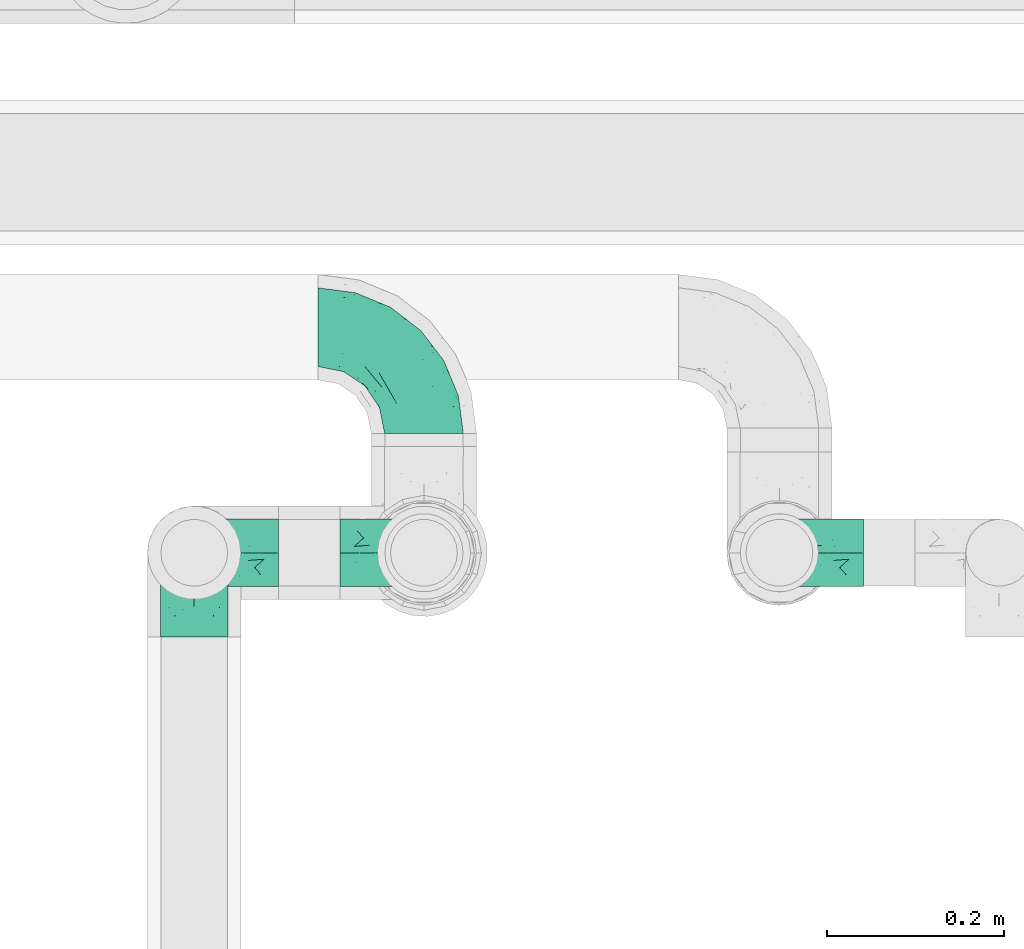
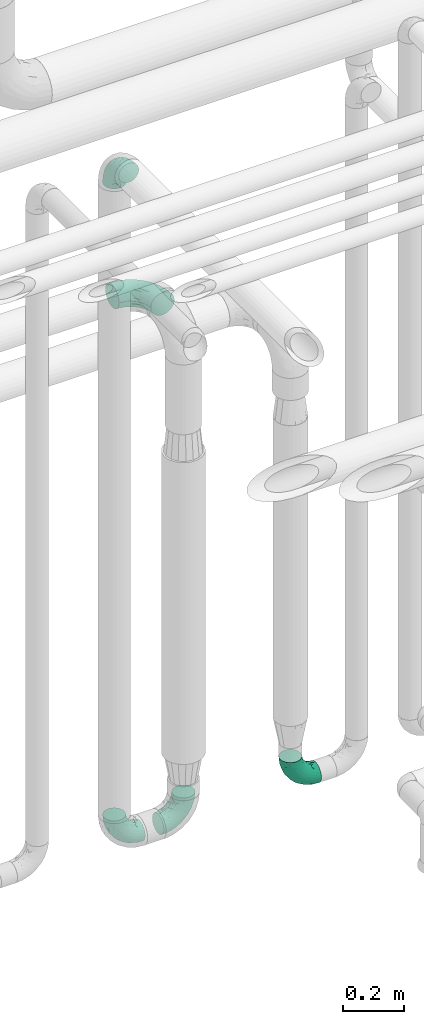
# One storey, part 709 of 824: 5 flow fittings.
"""IFC2X3 building model written with IfcOpenShell, lengths in millimetres."""

from ifc_helpers import new_model, entity, si_unit, converted_unit, derived_unit, direction, frame, origin, place, context, subcontext, project, spatial, faceted_brep, source, transform, mapped, material, type_object, type_shapes, element, save


model = new_model("IFC2X3")

# Units and contexts
model_context = context("Model", 3, precision=0.01, world=origin(), true_north=direction((6.12303176911189e-17, 1.0)))
body_context = subcontext(model_context, "Body", "Model", "MODEL_VIEW")
ifc_project = project(units=[si_unit("LENGTHUNIT", "METRE", prefix="MILLI"), si_unit("AREAUNIT", "SQUARE_METRE"), si_unit("VOLUMEUNIT", "CUBIC_METRE"), converted_unit("PLANEANGLEUNIT", "DEGREE", entity("IfcRatioMeasure", 0.0174532925199433), si_unit("PLANEANGLEUNIT", "RADIAN"), dimensions=[0, 0, 0, 0, 0, 0, 0]), si_unit("MASSUNIT", "GRAM", prefix="KILO"), derived_unit("MASSDENSITYUNIT", [(si_unit("MASSUNIT", "GRAM", prefix="KILO"), 1), (si_unit("LENGTHUNIT", "METRE"), -3)]), derived_unit("MOMENTOFINERTIAUNIT", [(si_unit("LENGTHUNIT", "METRE"), 4)]), si_unit("TIMEUNIT", "SECOND"), si_unit("FREQUENCYUNIT", "HERTZ"), si_unit("THERMODYNAMICTEMPERATUREUNIT", "DEGREE_CELSIUS"), derived_unit("THERMALTRANSMITTANCEUNIT", [(si_unit("MASSUNIT", "GRAM", prefix="KILO"), 1), (si_unit("THERMODYNAMICTEMPERATUREUNIT", "KELVIN"), -1), (si_unit("TIMEUNIT", "SECOND"), -3)]), derived_unit("VOLUMETRICFLOWRATEUNIT", [(si_unit("LENGTHUNIT", "METRE"), 3), (si_unit("TIMEUNIT", "SECOND"), -1)]), derived_unit("MASSFLOWRATEUNIT", [(si_unit("MASSUNIT", "GRAM", prefix="KILO"), 1), (si_unit("TIMEUNIT", "SECOND"), -1)]), derived_unit("ROTATIONALFREQUENCYUNIT", [(si_unit("TIMEUNIT", "SECOND"), -1)]), si_unit("ELECTRICCURRENTUNIT", "AMPERE"), si_unit("ELECTRICVOLTAGEUNIT", "VOLT"), si_unit("POWERUNIT", "WATT"), si_unit("FORCEUNIT", "NEWTON", prefix="KILO"), si_unit("ILLUMINANCEUNIT", "LUX"), si_unit("LUMINOUSFLUXUNIT", "LUMEN"), si_unit("LUMINOUSINTENSITYUNIT", "CANDELA"), derived_unit("USERDEFINED", [(si_unit("MASSUNIT", "GRAM", prefix="KILO"), -1), (si_unit("LENGTHUNIT", "METRE"), -2), (si_unit("TIMEUNIT", "SECOND"), 3), (si_unit("LUMINOUSFLUXUNIT", "LUMEN"), 1)]), derived_unit("LINEARVELOCITYUNIT", [(si_unit("LENGTHUNIT", "METRE"), 1), (si_unit("TIMEUNIT", "SECOND"), -1)]), si_unit("PRESSUREUNIT", "PASCAL"), derived_unit("USERDEFINED", [(si_unit("LENGTHUNIT", "METRE"), -2), (si_unit("MASSUNIT", "GRAM", prefix="KILO"), 1), (si_unit("TIMEUNIT", "SECOND"), -2)]), derived_unit("LINEARFORCEUNIT", [(si_unit("MASSUNIT", "GRAM", prefix="KILO"), 1), (si_unit("LENGTHUNIT", "METRE"), 1), (si_unit("TIMEUNIT", "SECOND"), -2), (si_unit("LENGTHUNIT", "METRE"), -1)]), derived_unit("PLANARFORCEUNIT", [(si_unit("MASSUNIT", "GRAM", prefix="KILO"), 1), (si_unit("LENGTHUNIT", "METRE"), 1), (si_unit("TIMEUNIT", "SECOND"), -2), (si_unit("LENGTHUNIT", "METRE"), -2)])], contexts=[model_context])

# Site, building, storey
site_placement = place(None, origin())
site = spatial("IfcSite", under=ifc_project, at=site_placement, CompositionType="ELEMENT")
building_placement = place(site_placement, origin())
building = spatial("IfcBuilding", under=site, at=building_placement, CompositionType="ELEMENT")
storey_placement = place(building_placement, frame((0.0, 0.0, 28200.0)))
storey = spatial("IfcBuildingStorey", under=building, at=storey_placement, CompositionType="ELEMENT", Elevation=28200.0)

# Flow fittings
ifc_material = material()
pipe_fitting_type_1 = type_object("IfcPipeFittingType", PredefinedType="NOTDEFINED", material=ifc_material)
shared_shape_1 = source(origin(), body_context, "Body", "Brep", [
    faceted_brep([(-120.0, 22.25, -38.54), (-120.0, 11.52, -42.98), (-120.0, 0.0, -44.5), (-120.0, -11.52, -42.98), (-120.0, -22.25, -38.54), (-120.0, -31.47, -31.47), (-120.0, -38.54, -22.25), (-120.0, -42.98, -11.52), (-120.0, -44.5, 0.0), (-120.0, -42.98, 11.52), (-120.0, -38.54, 22.25), (-120.0, -31.47, 31.47), (-120.0, -22.25, 38.54), (-120.0, -11.52, 42.98), (-120.0, 0.0, 44.5), (-120.0, 11.52, 42.98), (-120.0, 22.25, 38.54), (-120.0, 31.47, 31.47), (-120.0, 38.54, 22.25), (-120.0, 42.98, 11.52), (-120.0, 44.5, 0.0), (-120.0, 42.98, -11.52), (-120.0, 38.54, -22.25), (-120.0, 31.47, -31.47), (0.0, 120.0, -44.5), (-11.52, 120.0, -42.98), (-22.25, 120.0, -38.54), (-31.47, 120.0, -31.47), (-38.54, 120.0, -22.25), (-42.98, 120.0, -11.52), (-44.5, 120.0, 0.0), (-42.98, 120.0, 11.52), (-38.54, 120.0, 22.25), (-31.47, 120.0, 31.47), (-22.25, 120.0, 38.54), (-11.52, 120.0, 42.98), (0.0, 120.0, 44.5), (11.52, 120.0, 42.98), (22.25, 120.0, 38.54), (31.47, 120.0, 31.47), (38.54, 120.0, 22.25), (42.98, 120.0, 11.52), (44.5, 120.0, 0.0), (42.98, 120.0, -11.52), (38.54, 120.0, -22.25), (31.47, 120.0, -31.47), (22.25, 120.0, -38.54), (11.52, 120.0, -42.98), (-20.51, 85.66, 41.98), (-29.31, 93.55, 36.45), (-98.0, -41.6, 0.0), (-80.92, -37.22, 14.68), (-66.68, -9.63, 39.67), (-84.59, -24.55, 33.9), (-50.35, -12.87, 32.85), (-77.42, -38.89, 0.0), (-22.01, -9.62, 13.21), (-37.75, -22.46, 0.0), (-20.72, -9.39, 0.0), (-89.18, -33.47, 25.4), (12.87, 50.35, 32.85), (24.55, 84.59, 33.9), (9.63, 66.68, 39.67), (-49.55, -27.06, 11.21), (-28.67, -9.99, 21.67), (-52.01, -22.41, 23.47), (-95.53, -16.28, 40.49), (-86.01, -3.42, 43.77), (22.41, 52.01, 23.47), (9.05, 21.37, 13.44), (26.5, 49.37, 12.73), (33.47, 89.18, 25.4), (37.22, 80.92, 14.68), (16.28, 95.53, 40.49), (3.42, 86.01, 43.77), (-7.84, 52.6, 43.16), (-84.39, 31.88, 36.84), (-30.52, 34.28, 44.33), (-21.99, 28.55, 42.22), (-93.56, 38.23, 28.63), (-65.04, 31.74, 41.51), (-91.98, 19.0, 41.83), (-34.03, 70.24, 39.41), (-96.36, 44.0, 18.64), (-98.49, 46.74, 8.65), (-76.5, 56.97, 9.76), (-4.96, 4.47, 11.32), (-7.16, 6.18, 18.93), (-56.62, 75.93, 12.18), (-66.61, 66.61, 0.0), (-92.12, 7.25, 44.33), (-7.23, 92.66, 44.32), (30.68, 57.59, 0.0), (-44.45, 94.8, 18.75), (-36.39, 101.98, 28.14), (-46.83, 97.45, 9.69), (-38.03, 47.61, 43.21), (-24.7, 65.7, 43.29), (41.6, 98.0, 0.0), (-54.11, 72.8, 21.53), (-47.95, 9.75, 42.93), (-18.65, 18.65, 37.89), (-91.11, 50.25, 0.0), (-50.25, 91.11, 0.0), (-57.59, -30.68, 0.0), (-44.16, 67.2, 34.92), (-55.15, 62.16, 29.74), (-68.1, 47.21, 32.31), (-51.09, 51.09, 38.36), (-16.69, 62.62, 44.46), (-58.26, 18.84, 44.48), (-71.55, 55.71, 20.49), (-43.13, 80.04, 29.45), (-37.23, 0.88, 36.78), (-18.15, 10.22, 33.09), (5.51, 28.08, 26.74), (-3.68, 3.68, 0.0), (9.39, 20.72, 0.0), (-2.58, 27.98, 33.59), (-2.38, 41.22, 38.93), (-16.09, 4.55, 27.06), (38.89, 77.42, 0.0), (22.46, 37.75, 0.0), (-92.66, 7.23, -44.32), (-22.01, -9.62, -13.21), (-49.81, -26.66, -12.91), (-28.67, -9.99, -21.67), (-62.62, 16.69, -44.46), (-65.04, 31.74, -41.51), (-38.89, 47.26, -43.11), (-56.62, 75.93, -12.18), (-93.56, 38.23, -28.63), (-84.39, 31.88, -36.84), (16.28, 95.53, -40.49), (3.42, 86.01, -43.77), (-98.49, 46.74, -8.65), (-44.45, 94.8, -18.75), (-54.11, 72.8, -21.53), (-76.5, 56.97, -9.76), (24.55, 84.59, -33.9), (9.63, 66.68, -39.67), (-96.36, 44.0, -18.64), (-29.4, 93.16, -36.47), (-91.98, 19.0, -41.83), (-80.92, -37.22, -14.68), (-52.6, 7.84, -43.16), (-86.01, -3.42, -43.77), (-89.18, -33.47, -25.4), (-52.01, -22.41, -23.47), (-50.35, -12.87, -32.85), (-84.59, -24.55, -33.9), (-66.68, -9.63, -39.67), (-95.53, -16.28, -40.49), (-68.1, 47.21, -32.31), (-35.81, 11.1, -40.85), (-19.61, 28.53, -41.59), (-18.65, 18.65, -37.89), (-4.97, 4.47, -11.34), (9.05, 21.37, -13.44), (-34.28, 30.52, -44.33), (-9.75, 47.95, -42.93), (-2.58, 27.98, -33.59), (-18.15, 10.22, -33.09), (-46.83, 97.45, -9.69), (12.87, 50.35, -32.85), (26.8, 49.13, -11.4), (-7.34, 92.03, -44.33), (-21.02, 83.86, -42.03), (-44.6, 66.82, -34.8), (-55.46, 62.18, -29.47), (37.22, 80.92, -14.68), (33.47, 89.18, -25.4), (-34.39, 70.11, -39.28), (-25.04, 64.41, -43.37), (-18.84, 58.26, -44.48), (22.41, 52.01, -23.47), (-36.39, 101.98, -28.14), (-51.09, 51.09, -38.36), (-43.13, 80.04, -29.45), (-71.55, 55.71, -20.49), (-7.15, 6.2, -18.94), (5.51, 28.08, -26.74), (-37.23, 0.88, -36.78), (-2.38, 41.22, -38.93), (-16.09, 4.55, -27.06)], [[[0, 1, 2, 3, 4, 5, 6, 7, 8, 9, 10, 11, 12, 13, 14, 15, 16, 17, 18, 19, 20, 21, 22, 23]], [[24, 25, 26, 27, 28, 29, 30, 31, 32, 33, 34, 35, 36, 37, 38, 39, 40, 41, 42, 43, 44, 45, 46, 47]], [[48, 34, 49]], [[50, 51, 9]], [[52, 53, 54]], [[9, 51, 10]], [[55, 51, 50]], [[56, 57, 58]], [[51, 59, 10]], [[60, 61, 62]], [[63, 64, 65]], [[13, 12, 66]], [[67, 14, 13]], [[68, 69, 70]], [[71, 68, 72]], [[38, 73, 61]], [[74, 75, 62]], [[17, 16, 76]], [[77, 78, 75]], [[79, 18, 17]], [[80, 76, 81]], [[35, 34, 48]], [[49, 82, 48]], [[18, 83, 19]], [[16, 81, 76]], [[20, 19, 84]], [[85, 84, 83]], [[56, 86, 87]], [[85, 88, 89]], [[37, 36, 74]], [[90, 14, 67]], [[79, 17, 76]], [[63, 65, 51]], [[13, 66, 67]], [[61, 39, 38]], [[91, 74, 36]], [[70, 92, 72]], [[93, 94, 32]], [[95, 88, 93]], [[62, 73, 74]], [[82, 96, 97]], [[40, 72, 41]], [[72, 68, 70]], [[71, 72, 40]], [[34, 33, 49]], [[72, 98, 41]], [[99, 93, 88]], [[71, 39, 61]], [[78, 100, 101]], [[85, 89, 102]], [[53, 52, 66]], [[103, 95, 30]], [[12, 11, 53]], [[103, 89, 88]], [[104, 57, 63]], [[91, 48, 97]], [[93, 32, 31]], [[33, 32, 94]], [[16, 15, 81]], [[105, 106, 107]], [[76, 107, 79]], [[35, 91, 36]], [[80, 96, 108]], [[31, 95, 93]], [[65, 53, 59]], [[73, 38, 37]], [[75, 74, 109]], [[61, 60, 68]], [[11, 10, 59]], [[54, 53, 65]], [[100, 67, 52]], [[110, 81, 90]], [[15, 14, 90]], [[76, 80, 108]], [[107, 76, 108]], [[83, 79, 111]], [[94, 49, 33]], [[82, 105, 108]], [[84, 85, 102]], [[111, 88, 85]], [[99, 88, 111]], [[94, 93, 112]], [[48, 91, 35]], [[74, 91, 109]], [[69, 87, 86]], [[113, 54, 114]], [[64, 56, 87]], [[60, 115, 68]], [[116, 117, 86]], [[69, 68, 115]], [[79, 83, 18]], [[85, 83, 111]], [[81, 110, 80]], [[110, 77, 96]], [[110, 96, 80]], [[97, 96, 109]], [[107, 108, 105]], [[111, 79, 107]], [[77, 75, 109]], [[118, 119, 101]], [[96, 77, 109]], [[77, 110, 100]], [[67, 100, 110]], [[100, 52, 113]], [[60, 119, 118]], [[118, 120, 115]], [[64, 54, 65]], [[114, 120, 118]], [[118, 115, 60]], [[115, 120, 87]], [[74, 73, 37]], [[61, 73, 62]], [[53, 66, 12]], [[67, 66, 52]], [[110, 90, 67]], [[15, 90, 81]], [[105, 49, 112]], [[96, 82, 108]], [[119, 60, 62]], [[118, 101, 114]], [[62, 75, 119]], [[78, 119, 75]], [[49, 105, 82]], [[105, 112, 106]], [[99, 112, 93]], [[111, 107, 106]], [[113, 114, 101]], [[54, 120, 114]], [[100, 113, 101]], [[52, 54, 113]], [[20, 84, 102]], [[83, 84, 19]], [[111, 106, 99]], [[112, 99, 106]], [[100, 78, 77]], [[119, 78, 101]], [[39, 71, 40]], [[68, 71, 61]], [[65, 59, 51]], [[11, 59, 53]], [[30, 95, 31]], [[103, 88, 95]], [[9, 8, 50]], [[98, 72, 121]], [[98, 42, 41]], [[49, 94, 112]], [[56, 63, 57]], [[51, 55, 104]], [[92, 121, 72]], [[86, 58, 116]], [[54, 64, 120]], [[115, 87, 69]], [[120, 64, 87]], [[58, 86, 56]], [[86, 117, 69]], [[91, 97, 109]], [[122, 69, 117]], [[82, 97, 48]], [[63, 56, 64]], [[104, 63, 51]], [[69, 122, 70]], [[92, 70, 122]], [[123, 2, 1]], [[124, 125, 126]], [[127, 128, 129]], [[103, 130, 89]], [[23, 131, 132]], [[47, 133, 134]], [[102, 135, 20]], [[130, 136, 137]], [[102, 138, 135]], [[139, 140, 133]], [[22, 21, 141]], [[27, 26, 142]], [[46, 45, 139]], [[0, 143, 1]], [[6, 144, 7]], [[145, 146, 127]], [[144, 50, 7]], [[147, 148, 144]], [[144, 6, 147]], [[149, 150, 151]], [[4, 3, 152]], [[23, 22, 131]], [[132, 131, 153]], [[43, 42, 98]], [[125, 104, 144]], [[154, 155, 156]], [[146, 151, 152]], [[4, 150, 5]], [[123, 146, 2]], [[157, 158, 117]], [[130, 138, 89]], [[29, 28, 136]], [[159, 160, 155]], [[161, 162, 156]], [[89, 138, 102]], [[163, 30, 29]], [[164, 140, 139]], [[163, 136, 130]], [[23, 132, 0]], [[158, 165, 122]], [[25, 24, 166]], [[0, 132, 143]], [[4, 152, 150]], [[142, 26, 167]], [[3, 2, 146]], [[167, 26, 25]], [[133, 47, 46]], [[168, 153, 169]], [[146, 145, 151]], [[149, 126, 148]], [[44, 170, 171]], [[24, 47, 134]], [[170, 44, 43]], [[144, 148, 125]], [[170, 98, 121]], [[168, 142, 172]], [[129, 173, 174]], [[98, 170, 43]], [[147, 5, 150]], [[157, 58, 124]], [[92, 122, 165]], [[134, 166, 24]], [[175, 139, 171]], [[28, 27, 176]], [[29, 136, 163]], [[132, 128, 143]], [[45, 44, 171]], [[164, 139, 175]], [[160, 134, 140]], [[174, 173, 166]], [[141, 131, 22]], [[132, 153, 177]], [[128, 132, 177]], [[123, 143, 127]], [[172, 142, 167]], [[176, 142, 178]], [[130, 179, 138]], [[138, 179, 141]], [[176, 136, 28]], [[130, 137, 179]], [[174, 166, 134]], [[167, 25, 166]], [[143, 123, 1]], [[146, 123, 127]], [[150, 149, 148]], [[157, 124, 180]], [[181, 161, 164]], [[181, 158, 180]], [[124, 126, 180]], [[170, 165, 175]], [[141, 21, 135]], [[131, 141, 179]], [[131, 179, 153]], [[179, 137, 169]], [[129, 128, 177]], [[127, 143, 128]], [[129, 177, 172]], [[129, 174, 159]], [[159, 145, 127]], [[182, 154, 156]], [[129, 159, 127]], [[159, 174, 160]], [[134, 160, 174]], [[140, 164, 183]], [[162, 182, 156]], [[126, 149, 184]], [[181, 164, 175]], [[164, 161, 183]], [[158, 181, 175]], [[184, 162, 161]], [[146, 152, 3]], [[150, 152, 151]], [[139, 133, 46]], [[134, 133, 140]], [[184, 161, 181]], [[161, 156, 183]], [[155, 183, 156]], [[160, 140, 183]], [[184, 149, 162]], [[182, 162, 149]], [[149, 151, 182]], [[154, 151, 145]], [[151, 154, 182]], [[159, 154, 145]], [[159, 155, 154]], [[183, 155, 160]], [[141, 135, 138]], [[20, 135, 21]], [[136, 178, 137]], [[169, 178, 168]], [[172, 167, 173]], [[168, 172, 177]], [[153, 168, 177]], [[142, 168, 178]], [[179, 169, 153]], [[137, 178, 169]], [[5, 147, 6]], [[148, 147, 150]], [[175, 171, 170]], [[45, 171, 139]], [[130, 103, 163]], [[30, 163, 103]], [[50, 144, 55]], [[50, 8, 7]], [[142, 176, 27]], [[136, 176, 178]], [[126, 125, 148]], [[104, 55, 144]], [[170, 121, 92]], [[58, 57, 124]], [[180, 126, 184]], [[181, 180, 184]], [[180, 158, 157]], [[158, 122, 117]], [[58, 157, 116]], [[172, 173, 129]], [[116, 157, 117]], [[166, 173, 167]], [[124, 57, 125]], [[104, 125, 57]], [[175, 165, 158]], [[92, 165, 170]]]),
])
type_shapes(pipe_fitting_type_1, [shared_shape_1])
flow_fitting_placement = place(storey_placement, frame((58247.57, 17755.1, 2300.0), z_axis=(0.0, 0.0, 1.0), x_axis=(0.0, 1.0, 0.0)))
element("IfcFlowFitting", 1, at=flow_fitting_placement, inside=storey, type_object=pipe_fitting_type_1, material=ifc_material, context=body_context, shape_type="MappedRepresentation", body=[
    mapped(shared_shape_1, transform((0.0, 0.0, 0.0), scale=1.0)),
])
pipe_fitting_type_2 = type_object("IfcPipeFittingType", PredefinedType="NOTDEFINED", material=ifc_material)
shared_shape_2 = source(origin(), body_context, "Body", "Brep", [
    faceted_brep([(-95.0, 19.02, -32.95), (-95.0, 9.85, -36.75), (-95.0, 0.0, -38.05), (-95.0, -9.85, -36.75), (-95.0, -19.03, -32.95), (-95.0, -26.91, -26.91), (-95.0, -32.95, -19.03), (-95.0, -36.75, -9.85), (-95.0, -38.05, 0.0), (-95.0, -36.75, 9.85), (-95.0, -32.95, 19.02), (-95.0, -26.91, 26.91), (-95.0, -19.03, 32.95), (-95.0, -9.85, 36.75), (-95.0, 0.0, 38.05), (-95.0, 9.85, 36.75), (-95.0, 19.02, 32.95), (-95.0, 26.91, 26.91), (-95.0, 32.95, 19.02), (-95.0, 36.75, 9.85), (-95.0, 38.05, 0.0), (-95.0, 36.75, -9.85), (-95.0, 32.95, -19.03), (-95.0, 26.91, -26.91), (0.0, 95.0, -38.05), (-9.85, 95.0, -36.75), (-19.02, 95.0, -32.95), (-26.91, 95.0, -26.91), (-32.95, 95.0, -19.03), (-36.75, 95.0, -9.85), (-38.05, 95.0, 0.0), (-36.75, 95.0, 9.85), (-32.95, 95.0, 19.02), (-26.91, 95.0, 26.91), (-19.02, 95.0, 32.95), (-9.85, 95.0, 36.75), (0.0, 95.0, 38.05), (9.85, 95.0, 36.75), (19.03, 95.0, 32.95), (26.91, 95.0, 26.91), (32.95, 95.0, 19.02), (36.75, 95.0, 9.85), (38.05, 95.0, 0.0), (36.75, 95.0, -9.85), (32.95, 95.0, -19.03), (26.91, 95.0, -26.91), (19.03, 95.0, -32.95), (9.85, 95.0, -36.75), (-7.99, -4.96, 6.3), (-0.92, 0.92, 0.0), (4.62, 8.1, 8.01), (-76.19, -35.57, 0.0), (-64.32, -32.32, 12.43), (20.51, 62.45, 28.68), (-60.56, -33.52, 0.0), (-70.4, -13.47, 34.42), (-39.61, -5.88, 32.32), (-49.6, 2.07, 37.1), (-70.34, -28.81, 21.71), (14.64, 40.81, 26.5), (5.88, 39.61, 32.32), (3.59, 20.77, 25.31), (-40.45, 68.06, 16.75), (-62.45, -20.51, 28.68), (-44.52, -26.87, 0.0), (-28.47, -20.22, 0.0), (-26.43, -17.83, 8.75), (-76.1, 39.63, 10.76), (-72.74, 37.58, 18.19), (-60.35, 46.18, 14.61), (-13.4, 13.4, 32.12), (-20.77, -3.59, 25.31), (-14.66, 81.47, 35.56), (-6.22, 71.26, 37.92), (-57.5, 42.48, 22.79), (-15.0, 34.74, 37.7), (-27.1, 12.08, 36.05), (-9.2, 28.81, 35.63), (-79.98, 23.7, 30.95), (-73.68, -4.3, 37.48), (-30.74, 21.67, 37.97), (-62.36, 47.59, 6.79), (-72.71, 32.83, 24.69), (-67.42, 7.02, 37.95), (-32.13, 75.27, 24.51), (-43.46, 51.47, 26.26), (-24.98, 73.15, 31.29), (20.59, 41.28, 19.85), (7.79, 16.09, 15.86), (-73.21, 42.39, 0.0), (-54.73, 54.73, 0.0), (-73.44, 15.79, 35.79), (-5.94, 4.32, 20.43), (28.81, 70.34, 21.71), (32.32, 64.32, 12.43), (-53.59, 26.2, 35.09), (-52.02, 19.31, 37.21), (21.38, 33.53, 10.34), (26.87, 44.52, 0.0), (-48.28, 12.14, 38.05), (4.3, 73.68, 37.48), (-44.08, -25.52, 12.79), (-41.28, -20.59, 19.85), (35.57, 76.19, 0.0), (-47.26, 54.3, 20.18), (-47.4, 61.99, 8.58), (-42.39, 73.21, 0.0), (-39.67, 78.86, 7.21), (-45.69, 36.84, 33.11), (-32.83, 50.13, 33.35), (13.47, 70.4, 34.42), (-18.25, 63.73, 36.07), (-40.63, -13.75, 27.22), (-16.63, 46.37, 37.95), (-53.47, 38.79, 28.59), (-26.07, 48.54, 36.15), (-34.51, 34.51, 36.86), (-2.07, 49.6, 37.1), (-22.79, -10.49, 19.23), (-61.73, 28.67, 31.87), (9.65, 14.7, 0.0), (20.22, 28.47, 0.0), (33.52, 60.56, 0.0), (-11.42, -5.44, 13.25), (-14.7, -9.65, 0.0), (-81.47, 14.66, -35.56), (-62.45, -20.51, -28.68), (-71.26, 6.22, -37.92), (-75.27, 32.13, -24.51), (-73.15, 24.98, -31.29), (13.47, 70.4, -34.42), (5.88, 39.61, -32.32), (-2.07, 49.6, -37.1), (-78.86, 39.67, -7.21), (-70.4, -13.47, -34.42), (-39.61, -5.88, -32.32), (-61.99, 47.4, -8.58), (32.32, 64.32, -12.43), (28.81, 70.34, -21.71), (-63.73, 18.25, -36.07), (-50.13, 32.83, -33.35), (4.3, 73.68, -37.48), (-7.02, 67.42, -37.95), (-39.63, 76.1, -10.76), (-46.18, 60.35, -14.61), (-47.59, 62.36, -6.79), (-64.32, -32.32, -12.43), (-26.2, 53.59, -35.09), (-15.79, 73.44, -35.79), (-19.31, 52.02, -37.21), (-37.58, 72.74, -18.19), (-70.34, -28.81, -21.71), (-42.48, 57.5, -22.79), (-38.79, 53.47, -28.59), (-51.47, 43.46, -26.26), (-32.83, 72.71, -24.69), (-46.37, 16.63, -37.95), (-73.68, -4.3, -37.48), (-41.28, -20.59, -19.85), (-44.08, -25.52, -12.79), (13.75, 40.63, -27.22), (20.51, 62.45, -28.68), (-68.06, 40.45, -16.75), (-54.3, 47.26, -20.18), (-12.14, 48.28, -38.05), (-21.67, 30.74, -37.97), (-36.84, 45.69, -33.11), (-11.42, -5.44, -13.25), (7.79, 16.09, -15.86), (4.62, 8.1, -8.01), (-23.7, 79.98, -30.95), (-26.43, -17.83, -8.75), (-7.99, -4.96, -6.3), (-40.81, -14.64, -26.5), (-20.77, -3.59, -25.31), (-34.74, 15.0, -37.7), (-12.08, 27.1, -36.05), (-28.81, 9.2, -35.63), (-22.79, -10.49, -19.23), (21.38, 33.53, -10.34), (20.59, 41.28, -19.85), (-48.54, 26.07, -36.15), (-49.6, 2.07, -37.1), (-13.4, 13.4, -32.12), (3.59, 20.77, -25.31), (-28.67, 61.73, -31.87), (-34.51, 34.51, -36.86), (-5.94, 4.32, -20.43)], [[[0, 1, 2, 3, 4, 5, 6, 7, 8, 9, 10, 11, 12, 13, 14, 15, 16, 17, 18, 19, 20, 21, 22, 23]], [[24, 25, 26, 27, 28, 29, 30, 31, 32, 33, 34, 35, 36, 37, 38, 39, 40, 41, 42, 43, 44, 45, 46, 47]], [[48, 49, 50]], [[51, 52, 9]], [[53, 39, 38]], [[9, 52, 10]], [[54, 52, 51]], [[55, 56, 57]], [[11, 10, 58]], [[59, 60, 61]], [[32, 31, 62]], [[63, 12, 11]], [[63, 55, 12]], [[64, 65, 66]], [[67, 68, 69]], [[70, 56, 71]], [[35, 72, 73]], [[69, 68, 74]], [[75, 76, 77]], [[16, 78, 17]], [[13, 79, 14]], [[76, 75, 80]], [[67, 69, 81]], [[18, 17, 82]], [[14, 79, 83]], [[20, 19, 67]], [[84, 85, 86]], [[87, 61, 88]], [[89, 81, 90]], [[18, 82, 68]], [[15, 91, 16]], [[14, 83, 15]], [[71, 92, 61]], [[17, 78, 82]], [[93, 87, 94]], [[95, 91, 96]], [[97, 98, 94]], [[86, 72, 34]], [[96, 99, 80]], [[37, 36, 100]], [[40, 39, 93]], [[40, 94, 41]], [[64, 66, 101]], [[93, 94, 40]], [[58, 102, 63]], [[94, 103, 41]], [[94, 87, 97]], [[104, 69, 74]], [[34, 33, 86]], [[105, 69, 104]], [[52, 58, 10]], [[106, 107, 30]], [[108, 109, 85]], [[105, 106, 90]], [[53, 110, 60]], [[86, 111, 72]], [[86, 109, 111]], [[33, 84, 86]], [[12, 55, 13]], [[112, 56, 63]], [[110, 38, 37]], [[34, 72, 35]], [[36, 35, 73]], [[111, 113, 73]], [[105, 107, 106]], [[110, 53, 38]], [[74, 114, 85]], [[91, 15, 83]], [[105, 90, 81]], [[107, 62, 31]], [[33, 32, 84]], [[115, 109, 116]], [[111, 115, 113]], [[100, 73, 117]], [[56, 55, 63]], [[79, 55, 57]], [[102, 118, 112]], [[56, 70, 76]], [[100, 110, 37]], [[117, 77, 60]], [[117, 60, 110]], [[60, 70, 61]], [[58, 52, 101]], [[63, 11, 58]], [[39, 53, 93]], [[87, 93, 53]], [[96, 91, 83]], [[78, 91, 119]], [[32, 62, 84]], [[84, 62, 104]], [[86, 85, 109]], [[85, 114, 108]], [[80, 113, 116]], [[117, 73, 113]], [[80, 116, 96]], [[80, 57, 76]], [[71, 112, 118]], [[61, 87, 59]], [[62, 107, 105]], [[97, 120, 121]], [[70, 71, 61]], [[71, 118, 92]], [[73, 100, 36]], [[110, 100, 117]], [[55, 79, 13]], [[83, 79, 57]], [[96, 83, 99]], [[116, 108, 95]], [[50, 97, 88]], [[97, 87, 88]], [[50, 49, 120]], [[122, 94, 98]], [[89, 20, 67]], [[105, 81, 69]], [[89, 67, 81]], [[68, 19, 18]], [[68, 67, 19]], [[74, 68, 82]], [[114, 82, 119]], [[74, 85, 104]], [[82, 114, 74]], [[114, 119, 108]], [[95, 108, 119]], [[116, 109, 108]], [[123, 48, 50]], [[97, 50, 120]], [[123, 50, 88]], [[91, 95, 119]], [[116, 95, 96]], [[84, 104, 85]], [[104, 62, 105]], [[83, 57, 99]], [[57, 80, 99]], [[66, 48, 123]], [[66, 124, 48]], [[118, 66, 123]], [[124, 66, 65]], [[66, 118, 101]], [[54, 64, 52]], [[124, 49, 48]], [[30, 107, 31]], [[91, 78, 16]], [[82, 78, 119]], [[56, 76, 57]], [[77, 76, 70]], [[60, 77, 70]], [[77, 117, 75]], [[117, 113, 75]], [[113, 80, 75]], [[9, 8, 51]], [[103, 94, 122]], [[103, 42, 41]], [[73, 72, 111]], [[113, 115, 116]], [[111, 109, 115]], [[102, 112, 63]], [[71, 56, 112]], [[118, 102, 101]], [[92, 123, 88]], [[123, 92, 118]], [[61, 92, 88]], [[87, 53, 59]], [[60, 59, 53]], [[97, 121, 98]], [[58, 101, 102]], [[64, 101, 52]], [[125, 1, 0]], [[126, 5, 4]], [[2, 1, 127]], [[1, 125, 127]], [[128, 129, 23]], [[130, 131, 132]], [[89, 133, 20]], [[126, 134, 135]], [[136, 89, 90]], [[137, 138, 44]], [[139, 129, 140]], [[24, 141, 142]], [[143, 144, 145]], [[125, 129, 139]], [[6, 146, 7]], [[147, 148, 149]], [[146, 51, 7]], [[143, 150, 144]], [[146, 6, 151]], [[152, 153, 154]], [[126, 4, 134]], [[0, 23, 129]], [[28, 155, 150]], [[43, 42, 103]], [[54, 146, 64]], [[139, 156, 127]], [[157, 3, 2]], [[151, 158, 159]], [[160, 131, 161]], [[22, 21, 162]], [[136, 144, 163]], [[149, 164, 165]], [[24, 142, 25]], [[166, 140, 154]], [[154, 129, 128]], [[143, 30, 29]], [[167, 168, 169]], [[155, 28, 27]], [[26, 170, 27]], [[171, 167, 172]], [[26, 25, 148]], [[27, 170, 155]], [[173, 135, 174]], [[144, 150, 152]], [[175, 176, 177]], [[24, 47, 141]], [[45, 161, 46]], [[148, 25, 142]], [[176, 175, 165]], [[64, 159, 171]], [[138, 45, 44]], [[130, 46, 161]], [[137, 44, 43]], [[178, 159, 158]], [[137, 103, 122]], [[163, 144, 152]], [[136, 133, 89]], [[103, 137, 43]], [[6, 5, 151]], [[178, 158, 173]], [[134, 4, 3]], [[178, 173, 174]], [[137, 98, 179]], [[145, 90, 106]], [[138, 180, 161]], [[46, 130, 47]], [[136, 90, 145]], [[133, 162, 21]], [[23, 22, 128]], [[139, 140, 181]], [[139, 181, 156]], [[157, 127, 182]], [[157, 134, 3]], [[182, 177, 135]], [[182, 135, 134]], [[135, 183, 174]], [[131, 130, 161]], [[141, 130, 132]], [[160, 180, 184]], [[131, 183, 176]], [[5, 126, 151]], [[158, 151, 126]], [[180, 138, 137]], [[161, 45, 138]], [[149, 148, 142]], [[170, 148, 185]], [[22, 162, 128]], [[128, 162, 163]], [[129, 154, 140]], [[154, 153, 166]], [[165, 156, 186]], [[182, 127, 156]], [[165, 186, 149]], [[165, 132, 176]], [[131, 184, 183]], [[187, 167, 178]], [[184, 168, 187]], [[167, 169, 172]], [[184, 180, 168]], [[174, 183, 184]], [[127, 157, 2]], [[134, 157, 182]], [[130, 141, 47]], [[142, 141, 132]], [[149, 142, 164]], [[186, 166, 147]], [[180, 179, 168]], [[169, 179, 120]], [[137, 179, 180]], [[179, 121, 120]], [[106, 30, 143]], [[136, 145, 144]], [[106, 143, 145]], [[150, 29, 28]], [[150, 143, 29]], [[152, 150, 155]], [[153, 155, 185]], [[152, 154, 163]], [[155, 153, 152]], [[153, 185, 166]], [[147, 166, 185]], [[186, 140, 166]], [[169, 120, 49]], [[169, 49, 172]], [[179, 169, 168]], [[148, 147, 185]], [[186, 147, 149]], [[128, 163, 154]], [[163, 162, 136]], [[142, 132, 164]], [[132, 165, 164]], [[171, 124, 65]], [[124, 171, 172]], [[64, 146, 159]], [[171, 159, 178]], [[171, 65, 64]], [[172, 49, 124]], [[162, 133, 136]], [[20, 133, 21]], [[148, 170, 26]], [[155, 170, 185]], [[131, 176, 132]], [[177, 176, 183]], [[135, 177, 183]], [[177, 182, 175]], [[182, 156, 175]], [[156, 165, 175]], [[51, 146, 54]], [[51, 8, 7]], [[129, 125, 0]], [[127, 125, 139]], [[140, 186, 181]], [[156, 181, 186]], [[158, 126, 173]], [[135, 173, 126]], [[187, 178, 174]], [[171, 178, 167]], [[184, 187, 174]], [[167, 187, 168]], [[180, 160, 161]], [[184, 131, 160]], [[98, 137, 122]], [[98, 121, 179]], [[151, 159, 146]]]),
])
type_shapes(pipe_fitting_type_2, [shared_shape_2])
for number, where, z_axis, x_axis in (
    (2, (57987.89, 17500.0, 350.0), (0.0, -1.0, 0.0), (0.0, 0.0, -1.0)),
    (3, (58247.57, 17500.0, 350.0), (0.0, -1.0, 0.0), (1.0, 0.0, 0.0)),
    (4, (58649.38, 17500.0, 350.0), (0.0, 1.0, 0.0), (-1.0, 0.0, 0.0)),
    (5, (57987.89, 17500.0, 3050.0), (1.0, 0.0, 0.0), (0.0, 0.0, 1.0)),
):
    element("IfcFlowFitting", number, at=place(storey_placement, frame(where, z_axis=z_axis, x_axis=x_axis)), inside=storey, type_object=pipe_fitting_type_2, material=ifc_material, context=body_context, shape_type="MappedRepresentation", body=[
        mapped(shared_shape_2, transform((0.0, 0.0, 0.0), scale=1.0)),
    ])

save(model, "model.ifc")
